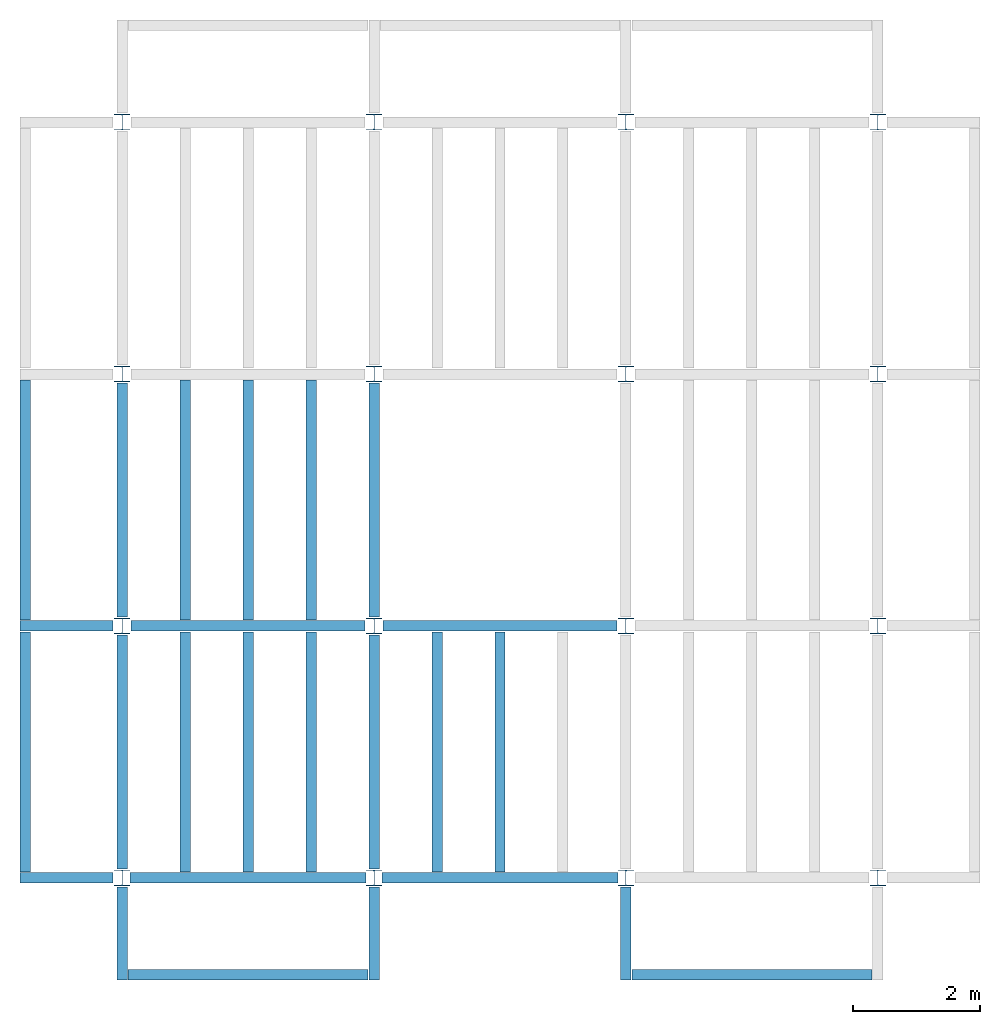
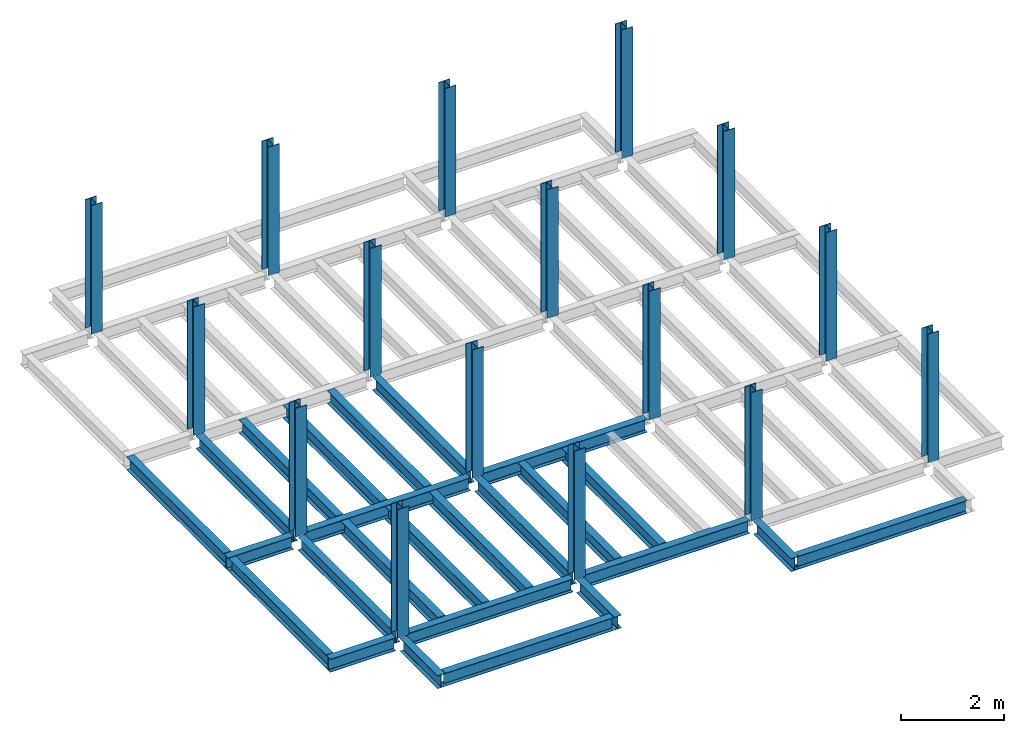
# One storey, part 1 of 3: 25 beams, 16 columns, 3 elements without a shape of their own.
"""IFC4 building model written with IfcOpenShell, lengths in feet."""

from ifc_helpers import new_model, entity, si_unit, converted_unit, derived_unit, direction, frame, origin, place, context, subcontext, project, spatial, line, arc, indexed_curve, outline, extrude, source, transform, mapped, material, type_object, type_shapes, element, aggregate, save


model = new_model("IFC4")

# Units and contexts
model_context = context("Model", 3, precision=0.0001, world=origin(), true_north=direction((6.123233995736766e-17, 1.0)))
plan_context = context("Plan", 3, precision=0.0001, world=origin(), true_north=direction((6.123233995736766e-17, 1.0)))
body_context = subcontext(model_context, "Body", "Model", "MODEL_VIEW")
ifc_project = project(units=[converted_unit("LENGTHUNIT", "FOOT", entity("IfcLengthMeasure", 0.3048), si_unit("LENGTHUNIT", "METRE"), dimensions=[1, 0, 0, 0, 0, 0, 0]), converted_unit("AREAUNIT", "SQUARE FOOT", entity("IfcAreaMeasure", 0.09290304), si_unit("AREAUNIT", "SQUARE_METRE"), dimensions=[2, 0, 0, 0, 0, 0, 0]), converted_unit("PLANEANGLEUNIT", "DEGREE", entity("IfcPlaneAngleMeasure", 0.017453292519943278), si_unit("PLANEANGLEUNIT", "RADIAN"), dimensions=[0, 0, 0, 0, 0, 0, 0]), converted_unit("VOLUMEUNIT", "CUBIC FOOT", entity("IfcVolumeMeasure", 0.028316846592000004), si_unit("VOLUMEUNIT", "CUBIC_METRE"), dimensions=[3, 0, 0, 0, 0, 0, 0]), si_unit("PRESSUREUNIT", "PASCAL"), derived_unit("MASSDENSITYUNIT", [(si_unit("MASSUNIT", "GRAM", prefix="KILO"), 1), (si_unit("LENGTHUNIT", "METRE"), -3)]), derived_unit("VAPORPERMEABILITYUNIT", [(si_unit("LENGTHUNIT", "METRE"), -1), (si_unit("TIMEUNIT", "SECOND"), 1)]), derived_unit("USERDEFINED", [(si_unit("MASSUNIT", "GRAM", prefix="KILO"), 1), (si_unit("LENGTHUNIT", "METRE"), 3), (si_unit("TIMEUNIT", "SECOND"), -3), (si_unit("ELECTRICCURRENTUNIT", "AMPERE"), -2)]), derived_unit("MODULUSOFELASTICITYUNIT", [(si_unit("MASSUNIT", "GRAM", prefix="KILO"), 1), (si_unit("LENGTHUNIT", "METRE"), -1), (si_unit("TIMEUNIT", "SECOND"), -2)]), derived_unit("THERMALEXPANSIONCOEFFICIENTUNIT", [(si_unit("THERMODYNAMICTEMPERATUREUNIT", "KELVIN"), -1)]), derived_unit("SPECIFICHEATCAPACITYUNIT", [(si_unit("TIMEUNIT", "SECOND"), -2), (si_unit("THERMODYNAMICTEMPERATUREUNIT", "KELVIN"), -1), (si_unit("LENGTHUNIT", "METRE"), 2)]), derived_unit("THERMALCONDUCTANCEUNIT", [(si_unit("MASSUNIT", "GRAM", prefix="KILO"), 1), (si_unit("TIMEUNIT", "SECOND"), -3), (si_unit("THERMODYNAMICTEMPERATUREUNIT", "KELVIN"), -1), (si_unit("LENGTHUNIT", "METRE"), 1)])], contexts=[model_context, plan_context])

# Site, building, storey
site_placement = place(None, origin())
site = spatial("IfcSite", under=ifc_project, at=site_placement, CompositionType="ELEMENT")
building_placement = place(site_placement, origin())
building = spatial("IfcBuilding", under=site, at=building_placement, CompositionType="ELEMENT")
storey_placement = place(building_placement, frame((0.0, 0.0, 79.875)))
storey = spatial("IfcBuildingStorey", under=building, at=storey_placement, Name="STR 09", CompositionType="ELEMENT", Elevation=79.875)

# Columns
ifc_material = material(Name="Steel ASTM A992", Category="Metal")
column_type = type_object("IfcColumnType", Name="W10X49", PredefinedType="COLUMN", material=ifc_material)
shared_shape_1 = source(origin(), body_context, "Body", "SweptSolid", [
    extrude(outline(indexed_curve([(-0.41666666666666663, -0.4166666666666676), (0.41666666666666663, -0.4166666666666676), (0.41666666666666663, -0.3699999999999996), (0.055833333333333846, -0.3699999999999996), (0.02637055078389421, -0.35779611588277277), (0.014166666666666636, -0.32833333333333287), (0.01416666666666665, 0.32833333333333303), (0.026370550783893467, 0.3577961158827727), (0.05583333333333332, 0.3700000000000003), (0.41666666666666663, 0.3700000000000003), (0.41666666666666663, 0.4166666666666656), (-0.41666666666666663, 0.4166666666666656), (-0.41666666666666663, 0.3700000000000003), (-0.05583333333333365, 0.3700000000000003), (-0.02637055078389416, 0.3577961158827734), (-0.014166666666666685, 0.32833333333333387), (-0.014166666666666685, -0.32833333333333264), (-0.026370550783893578, -0.3577961158827721), (-0.055833333333333374, -0.3699999999999996), (-0.41666666666666663, -0.3699999999999996)], segments=[line(1, 2, 3, 4), arc(4, 5, 6), line(6, 7), arc(7, 8, 9), line(9, 10, 11, 12, 13, 14), arc(14, 15, 16), line(16, 17), arc(17, 18, 19), line(19, 20, 1)], self_intersect=False)), frame((0.0, 0.0, 79.875), z_axis=(0.0, 0.0, 1.0), x_axis=(-1.0, 0.0, 0.0)), (0.0, 0.0, 1.0), 10.0),
])
type_shapes(column_type, [shared_shape_1])
for number, where, z_axis, x_axis, name in (
    (1, (0.0, 0.0, -79.875), (0.0, 0.0, 1.0), (-1.0, 0.0, 0.0), "W10X49"),
    (2, (0.0, 13.0, -79.875), (0.0, 0.0, 1.0), (-1.0, 0.0, 0.0), "W10X49"),
    (3, (0.0, 26.0, -79.875), (0.0, 0.0, 1.0), (-1.0, 0.0, 0.0), "W10X49"),
    (4, (0.0, 39.0, -79.875), (0.0, 0.0, 1.0), (-1.0, 0.0, 0.0), "W10X49"),
    (5, (13.0, 0.0, -79.875), (0.0, 0.0, 1.0), (-1.0, 0.0, 0.0), "W10X49"),
    (6, (13.0, 13.0, -79.875), (0.0, 0.0, 1.0), (-1.0, 0.0, 0.0), "W10X49"),
    (7, (13.0, 26.0, -79.875), (0.0, 0.0, 1.0), (-1.0, 0.0, 0.0), "W10X49"),
    (8, (13.0, 39.0, -79.875), (0.0, 0.0, 1.0), (-1.0, 0.0, 0.0), "W10X49"),
    (9, (26.0, 0.0, -79.875), (0.0, 0.0, 1.0), (-1.0, 0.0, 0.0), "W10X49"),
    (10, (26.0, 13.0, -79.875), (0.0, 0.0, 1.0), (-1.0, 0.0, 0.0), "W10X49"),
    (11, (26.0, 26.0, -79.875), (0.0, 0.0, 1.0), (-1.0, 0.0, 0.0), "W10X49"),
    (12, (26.0, 39.0, -79.875), (0.0, 0.0, 1.0), (-1.0, 0.0, 0.0), "W10X49"),
    (13, (39.0, 0.0, -79.875), (0.0, 0.0, 1.0), (-1.0, 0.0, 0.0), "W10X49"),
    (14, (39.0, 13.0, -79.875), (0.0, 0.0, 1.0), (-1.0, 0.0, 0.0), "W10X49"),
    (15, (39.0, 26.0, -79.875), (0.0, 0.0, 1.0), (-1.0, 0.0, 0.0), "W10X49"),
    (16, (39.0, 39.0, -79.875), (0.0, 0.0, 1.0), (-1.0, 0.0, 0.0), "W10X49"),
):
    element("IfcColumn", number, at=place(storey_placement, frame(where, z_axis=z_axis, x_axis=x_axis)), inside=storey, type_object=column_type, material=ifc_material, Name=name, ObjectType="W Shapes-Column:W10X49", PredefinedType="COLUMN", context=body_context, shape_type="MappedRepresentation", body=[
        mapped(shared_shape_1, transform((0.0, 0.0, 0.0), scale=1.0)),
    ])

# Beams
beam_type_1 = type_object("IfcBeamType", Name="W12X26", PredefinedType="JOIST", material=ifc_material)
shared_shape_2 = source(origin(), body_context, "Body", "SweptSolid", [
    extrude(outline(indexed_curve([(-0.27041666666666714, -0.47666666666666574), (-0.27041666666666714, -0.5083333333333351), (0.2704166666666669, -0.5083333333333351), (0.2704166666666669, -0.47666666666666574), (0.03458333333333309, -0.47666666666666574), (0.016905663803669493, -0.46934433619632937), (0.009583333333333202, -0.4516666666666659), (0.0095833333333332, 0.45166666666666705), (0.01690566380366948, 0.4693443361963307), (0.03458333333333325, 0.4766666666666671), (0.2704166666666669, 0.4766666666666671), (0.2704166666666669, 0.5083333333333312), (-0.2704166666666655, 0.5083333333333312), (-0.2704166666666655, 0.4766666666666671), (-0.034583333333333514, 0.47666666666666707), (-0.016905663803669865, 0.46934433619633054), (-0.009583333333333737, 0.45166666666666694), (-0.009583333333333735, -0.4516666666666658), (-0.01690566380367013, -0.4693443361963295), (-0.03458333333333368, -0.47666666666666574)], segments=[line(1, 2, 3, 4, 5), arc(5, 6, 7), line(7, 8), arc(8, 9, 10), line(10, 11, 12, 13, 14, 15), arc(15, 16, 17), line(17, 18), arc(18, 19, 20), line(20, 1)], self_intersect=False)), frame((-6.103346456692914, 0.0, 0.0), z_axis=(-1.0, 0.0, 0.0), x_axis=(0.0, -1.0, 0.0)), (0.0, 0.0, -1.0), 12.083333333333323),
])
type_shapes(beam_type_1, [shared_shape_2])
beam_1_placement = place(storey_placement, frame((6.561679790026266, 13.0, -0.50833333333334)))
element("IfcBeam", 17, at=beam_1_placement, inside=storey, type_object=beam_type_1, material=ifc_material, Name="W12X26", ObjectType="W Shapes:W12X26", PredefinedType="JOIST", context=body_context, shape_type="MappedRepresentation", body=[
    mapped(shared_shape_2, transform((0.0, 0.0, 0.0), scale=1.0)),
])
for number, where, z_axis, x_axis, name in (
    (18, (0.0, 6.561679790026247, -0.50833333333334), (0.0, 0.0, 1.0), (0.0, 1.0, 0.0), "W12X26"),
    (19, (13.0, 6.561679790026204, -0.50833333333334), (0.0, 0.0, 1.0), (0.0, 1.0, 0.0), "W12X26"),
):
    element("IfcBeam", number, at=place(storey_placement, frame(where, z_axis=z_axis, x_axis=x_axis)), inside=storey, type_object=beam_type_1, material=ifc_material, Name=name, ObjectType="W Shapes:W12X26", PredefinedType="JOIST", context=body_context, shape_type="MappedRepresentation", body=[
        mapped(shared_shape_2, transform((0.0, 0.0, 0.0), scale=1.0)),
    ])
beam_type_2 = type_object("IfcBeamType", Name="W12X26", PredefinedType="JOIST", material=ifc_material)
shared_shape_3 = source(origin(), body_context, "Body", "SweptSolid", [
    extrude(outline(indexed_curve([(-0.27041666666666714, -0.47666666666666574), (-0.27041666666666714, -0.5083333333333351), (0.2704166666666669, -0.5083333333333351), (0.2704166666666669, -0.47666666666666574), (0.03458333333333309, -0.47666666666666574), (0.016905663803669493, -0.46934433619632937), (0.009583333333333202, -0.4516666666666659), (0.0095833333333332, 0.45166666666666705), (0.01690566380366948, 0.4693443361963307), (0.03458333333333325, 0.4766666666666671), (0.2704166666666669, 0.4766666666666671), (0.2704166666666669, 0.5083333333333312), (-0.2704166666666655, 0.5083333333333312), (-0.2704166666666655, 0.4766666666666671), (-0.034583333333333514, 0.47666666666666707), (-0.016905663803669865, 0.46934433619633054), (-0.009583333333333737, 0.45166666666666694), (-0.009583333333333735, -0.4516666666666658), (-0.01690566380367013, -0.4693443361963295), (-0.03458333333333368, -0.47666666666666574)], segments=[line(1, 2, 3, 4, 5), arc(5, 6, 7), line(7, 8), arc(8, 9, 10), line(10, 11, 12, 13, 14, 15), arc(15, 16, 17), line(17, 18), arc(18, 19, 20), line(20, 1)], self_intersect=False)), frame((-6.226706036745409, 0.0, 0.0), z_axis=(-1.0, 0.0, 0.0), x_axis=(0.0, -1.0, 0.0)), (0.0, 0.0, -1.0), 12.08333333333333),
])
type_shapes(beam_type_2, [shared_shape_3])
beam_2_placement = place(storey_placement, frame((19.68503937007876, 13.0, -0.50833333333334)))
element("IfcBeam", 20, at=beam_2_placement, inside=storey, type_object=beam_type_2, material=ifc_material, Name="W12X26", ObjectType="W Shapes:W12X26", PredefinedType="JOIST", context=body_context, shape_type="MappedRepresentation", body=[
    mapped(shared_shape_3, transform((0.0, 0.0, 0.0), scale=1.0)),
])
for number, where, z_axis, x_axis, name in (
    (21, (0.0, 19.68503937007874, -0.50833333333334), (0.0, 0.0, 1.0), (0.0, 1.0, 0.0), "W12X26"),
    (22, (13.0, 19.685039370078698, -0.50833333333334), (0.0, 0.0, 1.0), (0.0, 1.0, 0.0), "W12X26"),
):
    element("IfcBeam", number, at=place(storey_placement, frame(where, z_axis=z_axis, x_axis=x_axis)), inside=storey, type_object=beam_type_2, material=ifc_material, Name=name, ObjectType="W Shapes:W12X26", PredefinedType="JOIST", context=body_context, shape_type="MappedRepresentation", body=[
        mapped(shared_shape_3, transform((0.0, 0.0, 0.0), scale=1.0)),
    ])

# Assembly, beams
assembly_1_placement = place(storey_placement, origin())
assembly_1 = element("IfcElementAssembly", 23, at=assembly_1_placement, inside=storey, Name="Structural Framing System", ObjectType="Structural Beam System:Structural Framing System", AssemblyPlace="NOTDEFINED", PredefinedType="BEAM_GRID")
beam_type_3 = type_object("IfcBeamType", Name="W12X26", PredefinedType="JOIST", material=ifc_material)
shared_shape_4 = source(origin(), body_context, "Body", "SweptSolid", [
    extrude(outline(indexed_curve([(-0.27041666666666714, -0.47666666666666574), (-0.27041666666666714, -0.5083333333333351), (0.2704166666666669, -0.5083333333333351), (0.2704166666666669, -0.47666666666666574), (0.03458333333333309, -0.47666666666666574), (0.016905663803669493, -0.46934433619632937), (0.009583333333333202, -0.4516666666666659), (0.0095833333333332, 0.45166666666666705), (0.01690566380366948, 0.4693443361963307), (0.03458333333333325, 0.4766666666666671), (0.2704166666666669, 0.4766666666666671), (0.2704166666666669, 0.5083333333333312), (-0.2704166666666655, 0.5083333333333312), (-0.2704166666666655, 0.4766666666666671), (-0.034583333333333514, 0.47666666666666707), (-0.016905663803669865, 0.46934433619633054), (-0.009583333333333737, 0.45166666666666694), (-0.009583333333333735, -0.4516666666666658), (-0.01690566380367013, -0.4693443361963295), (-0.03458333333333368, -0.47666666666666574)], segments=[line(1, 2, 3, 4, 5), arc(5, 6, 7), line(7, 8), arc(8, 9, 10), line(10, 11, 12, 13, 14, 15), arc(15, 16, 17), line(17, 18), arc(18, 19, 20), line(20, 1)], self_intersect=False)), frame((-6.187916666666566, 0.0, 0.0), z_axis=(-1.0, 0.0, 0.0), x_axis=(0.0, -1.0, 0.0)), (0.0, 0.0, -1.0), 12.375833333333075),
])
type_shapes(beam_type_3, [shared_shape_4])
beam_3_placement = place(assembly_1_placement, frame((3.250000000000031, 6.499999999999844, -0.50833333333334), z_axis=(0.0, 0.0, 1.0), x_axis=(0.0, 1.0, 0.0)))
beam_3 = element("IfcBeam", 24, at=beam_3_placement, type_object=beam_type_3, material=ifc_material, Name="W12X26", ObjectType="W Shapes:W12X26", PredefinedType="JOIST", context=body_context, shape_type="MappedRepresentation", body=[
    mapped(shared_shape_4, transform((0.0, 0.0, 0.0), scale=1.0)),
])
beam_4_placement = place(assembly_1_placement, frame((6.5000000000000515, 6.4999999999998455, -0.50833333333334), z_axis=(0.0, 0.0, 1.0), x_axis=(0.0, 1.0, 0.0)))
beam_4 = element("IfcBeam", 25, at=beam_4_placement, type_object=beam_type_3, material=ifc_material, Name="W12X26", ObjectType="W Shapes:W12X26", PredefinedType="JOIST", context=body_context, shape_type="MappedRepresentation", body=[
    mapped(shared_shape_4, transform((0.0, 0.0, 0.0), scale=1.0)),
])
beam_5_placement = place(assembly_1_placement, frame((9.750000000000073, 6.499999999999844, -0.50833333333334), z_axis=(0.0, 0.0, 1.0), x_axis=(0.0, 1.0, 0.0)))
beam_5 = element("IfcBeam", 26, at=beam_5_placement, type_object=beam_type_3, material=ifc_material, Name="W12X26", ObjectType="W Shapes:W12X26", PredefinedType="JOIST", context=body_context, shape_type="MappedRepresentation", body=[
    mapped(shared_shape_4, transform((0.0, 0.0, 0.0), scale=1.0)),
])
aggregate(assembly_1, [beam_3, beam_4, beam_5])

assembly_2_placement = place(storey_placement, origin())
assembly_2 = element("IfcElementAssembly", 27, at=assembly_2_placement, inside=storey, Name="Structural Framing System", ObjectType="Structural Beam System:Structural Framing System", AssemblyPlace="NOTDEFINED", PredefinedType="BEAM_GRID")
beam_6_placement = place(assembly_2_placement, frame((3.2500000000000515, 19.49999999999968, -0.50833333333334), z_axis=(0.0, 0.0, 1.0), x_axis=(0.0, 1.0, 0.0)))
beam_6 = element("IfcBeam", 28, at=beam_6_placement, type_object=beam_type_3, material=ifc_material, Name="W12X26", ObjectType="W Shapes:W12X26", PredefinedType="JOIST", context=body_context, shape_type="MappedRepresentation", body=[
    mapped(shared_shape_4, transform((0.0, 0.0, 0.0), scale=1.0)),
])
beam_7_placement = place(assembly_2_placement, frame((6.500000000000073, 19.499999999999666, -0.50833333333334), z_axis=(0.0, 0.0, 1.0), x_axis=(0.0, 1.0, 0.0)))
beam_7 = element("IfcBeam", 29, at=beam_7_placement, type_object=beam_type_3, material=ifc_material, Name="W12X26", ObjectType="W Shapes:W12X26", PredefinedType="JOIST", context=body_context, shape_type="MappedRepresentation", body=[
    mapped(shared_shape_4, transform((0.0, 0.0, 0.0), scale=1.0)),
])
beam_8_placement = place(assembly_2_placement, frame((9.750000000000094, 19.49999999999966, -0.50833333333334), z_axis=(0.0, 0.0, 1.0), x_axis=(0.0, 1.0, 0.0)))
beam_8 = element("IfcBeam", 30, at=beam_8_placement, type_object=beam_type_3, material=ifc_material, Name="W12X26", ObjectType="W Shapes:W12X26", PredefinedType="JOIST", context=body_context, shape_type="MappedRepresentation", body=[
    mapped(shared_shape_4, transform((0.0, 0.0, 0.0), scale=1.0)),
])
aggregate(assembly_2, [beam_6, beam_7, beam_8])

assembly_3_placement = place(storey_placement, origin())
assembly_3 = element("IfcElementAssembly", 31, at=assembly_3_placement, inside=storey, Name="Structural Framing System", ObjectType="Structural Beam System:Structural Framing System", AssemblyPlace="NOTDEFINED", PredefinedType="BEAM_GRID")
beam_9_placement = place(assembly_3_placement, frame((16.25000000000009, 6.499999999999801, -0.50833333333334), z_axis=(0.0, 0.0, 1.0), x_axis=(0.0, 1.0, 0.0)))
beam_9 = element("IfcBeam", 32, at=beam_9_placement, type_object=beam_type_3, material=ifc_material, Name="W12X26", ObjectType="W Shapes:W12X26", PredefinedType="JOIST", context=body_context, shape_type="MappedRepresentation", body=[
    mapped(shared_shape_4, transform((0.0, 0.0, 0.0), scale=1.0)),
])
beam_10_placement = place(assembly_3_placement, frame((19.500000000000096, 6.499999999999801, -0.50833333333334), z_axis=(0.0, 0.0, 1.0), x_axis=(0.0, 1.0, 0.0)))
beam_10 = element("IfcBeam", 33, at=beam_10_placement, type_object=beam_type_3, material=ifc_material, Name="W12X26", ObjectType="W Shapes:W12X26", PredefinedType="JOIST", context=body_context, shape_type="MappedRepresentation", body=[
    mapped(shared_shape_4, transform((0.0, 0.0, 0.0), scale=1.0)),
])
aggregate(assembly_3, [beam_9, beam_10])

# Beams
for number, where, z_axis, x_axis, name in (
    (34, (-5.0, 6.499999999999858, -0.50833333333334), (0.0, 0.0, 1.0), (0.0, -1.0, 0.0), "W12X26"),
    (35, (-5.0, 19.499999999999705, -0.50833333333334), (0.0, 0.0, 1.0), (0.0, 1.0, 0.0), "W12X26"),
):
    element("IfcBeam", number, at=place(storey_placement, frame(where, z_axis=z_axis, x_axis=x_axis)), inside=storey, type_object=beam_type_3, material=ifc_material, Name=name, ObjectType="W Shapes:W12X26", PredefinedType="JOIST", context=body_context, shape_type="MappedRepresentation", body=[
        mapped(shared_shape_4, transform((0.0, 0.0, 0.0), scale=1.0)),
    ])
beam_type_4 = type_object("IfcBeamType", Name="W12X26", PredefinedType="JOIST", material=ifc_material)
shared_shape_5 = source(origin(), body_context, "Body", "SweptSolid", [
    extrude(outline(indexed_curve([(-0.27041666666666714, -0.47666666666666574), (-0.27041666666666714, -0.5083333333333351), (0.2704166666666669, -0.5083333333333351), (0.2704166666666669, -0.47666666666666574), (0.03458333333333309, -0.47666666666666574), (0.016905663803669493, -0.46934433619632937), (0.009583333333333202, -0.4516666666666659), (0.0095833333333332, 0.45166666666666705), (0.01690566380366948, 0.4693443361963307), (0.03458333333333325, 0.4766666666666671), (0.2704166666666669, 0.4766666666666671), (0.2704166666666669, 0.5083333333333312), (-0.2704166666666655, 0.5083333333333312), (-0.2704166666666655, 0.4766666666666671), (-0.034583333333333514, 0.47666666666666707), (-0.016905663803669865, 0.46934433619633054), (-0.009583333333333737, 0.45166666666666694), (-0.009583333333333735, -0.4516666666666658), (-0.01690566380367013, -0.4693443361963295), (-0.03458333333333368, -0.47666666666666574)], segments=[line(1, 2, 3, 4, 5), arc(5, 6, 7), line(7, 8), arc(8, 9, 10), line(10, 11, 12, 13, 14, 15), arc(15, 16, 17), line(17, 18), arc(18, 19, 20), line(20, 1)], self_intersect=False)), frame((-6.291666664666666, 0.0, 0.0), z_axis=(-1.0, 0.0, 0.0), x_axis=(0.0, -1.0, 0.0)), (0.0, 0.0, -1.0), 12.16666666466667),
])
type_shapes(beam_type_4, [shared_shape_5])
beam_11_placement = place(storey_placement, frame((19.70833333333342, 0.0, -0.50833333333334)))
element("IfcBeam", 36, at=beam_11_placement, inside=storey, type_object=beam_type_4, material=ifc_material, Name="W12X26", ObjectType="W Shapes:W12X26", PredefinedType="JOIST", context=body_context, shape_type="MappedRepresentation", body=[
    mapped(shared_shape_5, transform((0.0, 0.0, 0.0), scale=1.0)),
])
beam_type_5 = type_object("IfcBeamType", Name="W12X26", PredefinedType="JOIST", material=ifc_material)
shared_shape_6 = source(origin(), body_context, "Body", "SweptSolid", [
    extrude(outline(indexed_curve([(0.47666666666666574, -0.2704166666666672), (0.5083333333333351, -0.2704166666666672), (0.5083333333333351, 0.27041666666666686), (0.47666666666666574, 0.27041666666666686), (0.47666666666666574, 0.03458333333333307), (0.46934433619632937, 0.016905663803669473), (0.4516666666666659, 0.00958333333333318), (-0.45166666666666705, 0.00958333333333318), (-0.4693443361963307, 0.01690566380366946), (-0.4766666666666671, 0.03458333333333323), (-0.4766666666666671, 0.27041666666666686), (-0.5083333333333312, 0.27041666666666686), (-0.5083333333333312, -0.27041666666666553), (-0.4766666666666671, -0.27041666666666553), (-0.47666666666666707, -0.034583333333333535), (-0.46934433619633054, -0.016905663803669885), (-0.45166666666666694, -0.00958333333333376), (0.4516666666666658, -0.009583333333333756), (0.4693443361963295, -0.01690566380367015), (0.47666666666666574, -0.0345833333333337)], segments=[line(1, 2, 3, 4, 5), arc(5, 6, 7), line(7, 8), arc(8, 9, 10), line(10, 11, 12, 13, 14, 15), arc(15, 16, 17), line(17, 18), arc(18, 19, 20), line(20, 1)], self_intersect=False)), frame((-6.0833333333333295, 0.0, 0.0), z_axis=(1.0, 0.0, 0.0), x_axis=(0.0, 0.0, -1.0)), (0.0, 0.0, 1.0), 12.16666666666666),
])
type_shapes(beam_type_5, [shared_shape_6])
beam_12_placement = place(storey_placement, frame((6.500000000000082, 0.0, -0.50833333333334), z_axis=(0.0, 0.0, 1.0), x_axis=(-1.0, 0.0, 0.0)))
element("IfcBeam", 37, at=beam_12_placement, inside=storey, type_object=beam_type_5, material=ifc_material, Name="W12X26", ObjectType="W Shapes:W12X26", PredefinedType="JOIST", context=body_context, shape_type="MappedRepresentation", body=[
    mapped(shared_shape_6, transform((0.0, 0.0, 0.0), scale=1.0)),
])
beam_type_6 = type_object("IfcBeamType", Name="W12X26", PredefinedType="JOIST", material=ifc_material)
shared_shape_7 = source(origin(), body_context, "Body", "SweptSolid", [
    extrude(outline(indexed_curve([(0.47666666666666574, -0.2704166666666672), (0.5083333333333351, -0.2704166666666672), (0.5083333333333351, 0.27041666666666686), (0.47666666666666574, 0.27041666666666686), (0.47666666666666574, 0.03458333333333307), (0.46934433619632937, 0.016905663803669473), (0.4516666666666659, 0.00958333333333318), (-0.45166666666666705, 0.00958333333333318), (-0.4693443361963307, 0.01690566380366946), (-0.4766666666666671, 0.03458333333333323), (-0.4766666666666671, 0.27041666666666686), (-0.5083333333333312, 0.27041666666666686), (-0.5083333333333312, -0.27041666666666553), (-0.4766666666666671, -0.27041666666666553), (-0.47666666666666707, -0.034583333333333535), (-0.46934433619633054, -0.016905663803669885), (-0.45166666666666694, -0.00958333333333376), (0.4516666666666658, -0.009583333333333756), (0.4693443361963295, -0.01690566380367015), (0.47666666666666574, -0.0345833333333337)], segments=[line(1, 2, 3, 4, 5), arc(5, 6, 7), line(7, 8), arc(8, 9, 10), line(10, 11, 12, 13, 14, 15), arc(15, 16, 17), line(17, 18), arc(18, 19, 20), line(20, 1)], self_intersect=False)), frame((-2.0416666666666208, 0.0, 0.0), z_axis=(1.0, 0.0, 0.0), x_axis=(0.0, 0.0, -1.0)), (0.0, 0.0, 1.0), 4.812083333333336),
])
type_shapes(beam_type_6, [shared_shape_7])
for number, where, z_axis, x_axis, name in (
    (38, (26.0, -2.500000000000538, -0.50833333333334), (0.0, 0.0, 1.0), (0.0, -1.0, 0.0), "W12X26"),
    (39, (-2.499999999999853, 13.0, -0.50833333333334), (0.0, 0.0, 1.0), (-1.0, 0.0, 0.0), "W12X26"),
    (40, (-2.4999999999998743, 0.0, -0.50833333333334), (0.0, 0.0, 1.0), (-1.0, 0.0, 0.0), "W12X26"),
):
    element("IfcBeam", number, at=place(storey_placement, frame(where, z_axis=z_axis, x_axis=x_axis)), inside=storey, type_object=beam_type_6, material=ifc_material, Name=name, ObjectType="W Shapes:W12X26", PredefinedType="JOIST", context=body_context, shape_type="MappedRepresentation", body=[
        mapped(shared_shape_7, transform((0.0, 0.0, 0.0), scale=1.0)),
    ])
beam_type_7 = type_object("IfcBeamType", Name="W12X26", PredefinedType="JOIST", material=ifc_material)
shared_shape_8 = source(origin(), body_context, "Body", "SweptSolid", [
    extrude(outline(indexed_curve([(0.47666666666666574, -0.2704166666666672), (0.5083333333333351, -0.2704166666666672), (0.5083333333333351, 0.27041666666666686), (0.47666666666666574, 0.27041666666666686), (0.47666666666666574, 0.03458333333333307), (0.46934433619632937, 0.016905663803669473), (0.4516666666666659, 0.00958333333333318), (-0.45166666666666705, 0.00958333333333318), (-0.4693443361963307, 0.01690566380366946), (-0.4766666666666671, 0.03458333333333323), (-0.4766666666666671, 0.27041666666666686), (-0.5083333333333312, 0.27041666666666686), (-0.5083333333333312, -0.27041666666666553), (-0.4766666666666671, -0.27041666666666553), (-0.47666666666666707, -0.034583333333333535), (-0.46934433619633054, -0.016905663803669885), (-0.45166666666666694, -0.00958333333333376), (0.4516666666666658, -0.009583333333333756), (0.4693443361963295, -0.01690566380367015), (0.47666666666666574, -0.0345833333333337)], segments=[line(1, 2, 3, 4, 5), arc(5, 6, 7), line(7, 8), arc(8, 9, 10), line(10, 11, 12, 13, 14, 15), arc(15, 16, 17), line(17, 18), arc(18, 19, 20), line(20, 1)], self_intersect=False)), frame((-6.187916666666685, 0.0, 0.0), z_axis=(1.0, 0.0, 0.0), x_axis=(0.0, 0.0, -1.0)), (0.0, 0.0, 1.0), 12.375833333333318),
])
type_shapes(beam_type_7, [shared_shape_8])
beam_13_placement = place(storey_placement, frame((32.50000000000002, -5.0, -0.50833333333334)))
element("IfcBeam", 41, at=beam_13_placement, inside=storey, type_object=beam_type_7, material=ifc_material, Name="W Shapes:W12X26", ObjectType="W Shapes:W12X26", PredefinedType="JOIST", context=body_context, shape_type="MappedRepresentation", body=[
    mapped(shared_shape_8, transform((0.0, 0.0, 0.0), scale=1.0)),
])
beam_type_8 = type_object("IfcBeamType", Name="W12X26", PredefinedType="JOIST", material=ifc_material)
shared_shape_9 = source(origin(), body_context, "Body", "SweptSolid", [
    extrude(outline(indexed_curve([(-0.2704166666666641, -0.5083333333333258), (0.27041666666666764, -0.5083333333333258), (0.27041666666666764, -0.47666666666665947), (0.03458333333333563, -0.4766666666666737), (0.01690566380367109, -0.469344336196329), (0.009583333333335275, -0.451666666666668), (0.009583333333335275, 0.451666666666668), (0.01690566380367109, 0.469344336196329), (0.03458333333333563, 0.4766666666666737), (0.2704166666666694, 0.4766666666666737), (0.27041666666666764, 0.50833333333334), (-0.27041666666666586, 0.50833333333334), (-0.27041666666666586, 0.4766666666666737), (-0.03458333333333208, 0.4766666666666737), (-0.016905663803667537, 0.469344336196329), (-0.009583333333331723, 0.451666666666668), (-0.009583333333331723, -0.451666666666668), (-0.016905663803667537, -0.469344336196329), (-0.03458333333333208, -0.47666666666665947), (-0.27041666666666586, -0.47666666666665947)], segments=[line(1, 2, 3, 4), arc(4, 5, 6), line(6, 7), arc(7, 8, 9), line(9, 10, 11, 12, 13, 14), arc(14, 15, 16), line(16, 17), arc(17, 18, 19), line(19, 20, 1)], self_intersect=False)), frame((13.0, -0.45833333333387627, 79.36666666666665), z_axis=(0.0, -1.0, 0.0), x_axis=(-1.0, 0.0, 0.0)), (0.0, 0.0, 1.0), 4.812083333333337),
])
type_shapes(beam_type_8, [shared_shape_9])
beam_14_placement = place(storey_placement, frame((0.0, 0.0, -79.875)))
element("IfcBeam", 42, at=beam_14_placement, inside=storey, type_object=beam_type_8, material=ifc_material, Name="W12X26", ObjectType="W Shapes:W12X26", PredefinedType="JOIST", context=body_context, shape_type="MappedRepresentation", body=[
    mapped(shared_shape_9, transform((0.0, 0.0, 0.0), scale=1.0)),
])
beam_type_9 = type_object("IfcBeamType", Name="W12X26", PredefinedType="JOIST", material=ifc_material)
shared_shape_10 = source(origin(), body_context, "Body", "SweptSolid", [
    extrude(outline(indexed_curve([(-0.5083333333333258, -0.270416666666665), (-0.47666666666665947, -0.270416666666665), (-0.4766666666666737, -0.034583333333333854), (-0.469344336196329, -0.016905663803669313), (-0.451666666666668, -0.009583333333333499), (0.451666666666668, -0.009583333333333499), (0.469344336196329, -0.016905663803669313), (0.4766666666666737, -0.034583333333332966), (0.4766666666666737, -0.27041666666666675), (0.50833333333334, -0.27041666666666675), (0.50833333333334, 0.27041666666666675), (0.4766666666666737, 0.27041666666666764), (0.4766666666666737, 0.034583333333333854), (0.469344336196329, 0.016905663803669313), (0.451666666666668, 0.009583333333333499), (-0.451666666666668, 0.009583333333333499), (-0.469344336196329, 0.016905663803669313), (-0.47666666666665947, 0.034583333333332966), (-0.47666666666665947, 0.27041666666666675), (-0.5083333333333258, 0.27041666666666764)], segments=[line(1, 2, 3), arc(3, 4, 5), line(5, 6), arc(6, 7, 8), line(8, 9, 10, 11, 12, 13), arc(13, 14, 15), line(15, 16), arc(16, 17, 18), line(18, 19, 20, 1)], self_intersect=False)), frame((0.3120833333333186, -5.0, 79.36666666666665), z_axis=(1.0, 0.0, 0.0), x_axis=(0.0, 0.0, -1.0)), (0.0, 0.0, 1.0), 12.37583333333332),
])
type_shapes(beam_type_9, [shared_shape_10])
beam_15_placement = place(storey_placement, frame((0.0, 0.0, -79.875)))
element("IfcBeam", 43, at=beam_15_placement, inside=storey, type_object=beam_type_9, material=ifc_material, Name="W Shapes:W12X26", ObjectType="W Shapes:W12X26", PredefinedType="JOIST", context=body_context, shape_type="MappedRepresentation", body=[
    mapped(shared_shape_10, transform((0.0, 0.0, 0.0), scale=1.0)),
])
beam_type_10 = type_object("IfcBeamType", Name="W12X26", PredefinedType="JOIST", material=ifc_material)
shared_shape_11 = source(origin(), body_context, "Body", "SweptSolid", [
    extrude(outline(indexed_curve([(-0.27041666666666686, -0.5083333333333258), (0.27041666666666553, -0.5083333333333258), (0.27041666666666553, -0.47666666666665947), (0.03458333333333355, -0.4766666666666737), (0.016905663803669275, -0.469344336196329), (0.009583333333333723, -0.451666666666668), (0.009583333333333218, 0.451666666666668), (0.01690566380366942, 0.469344336196329), (0.034583333333333716, 0.4766666666666737), (0.2704166666666672, 0.4766666666666737), (0.2704166666666672, 0.50833333333334), (-0.27041666666666686, 0.50833333333334), (-0.27041666666666686, 0.4766666666666737), (-0.03458333333333308, 0.4766666666666737), (-0.01690566380366875, 0.469344336196329), (-0.009583333333333164, 0.451666666666668), (-0.009583333333332694, -0.451666666666668), (-0.01690566380366881, -0.469344336196329), (-0.03458333333333319, -0.47666666666665947), (-0.27041666666666686, -0.47666666666665947)], segments=[line(1, 2, 3, 4), arc(4, 5, 6), line(6, 7), arc(7, 8, 9), line(9, 10, 11, 12, 13, 14), arc(14, 15, 16), line(16, 17), arc(17, 18, 19), line(19, 20, 1)], self_intersect=False)), frame((0.0, -0.45833333333383364, 79.36666666666665), z_axis=(0.0, -1.0, 0.0), x_axis=(-1.0, 0.0, 0.0)), (0.0, 0.0, 1.0), 4.812083333333337),
])
type_shapes(beam_type_10, [shared_shape_11])
beam_16_placement = place(storey_placement, frame((0.0, 0.0, -79.875)))
element("IfcBeam", 44, at=beam_16_placement, inside=storey, type_object=beam_type_10, material=ifc_material, Name="W12X26", ObjectType="W Shapes:W12X26", PredefinedType="JOIST", context=body_context, shape_type="MappedRepresentation", body=[
    mapped(shared_shape_11, transform((0.0, 0.0, 0.0), scale=1.0)),
])

save(model, "model.ifc")
